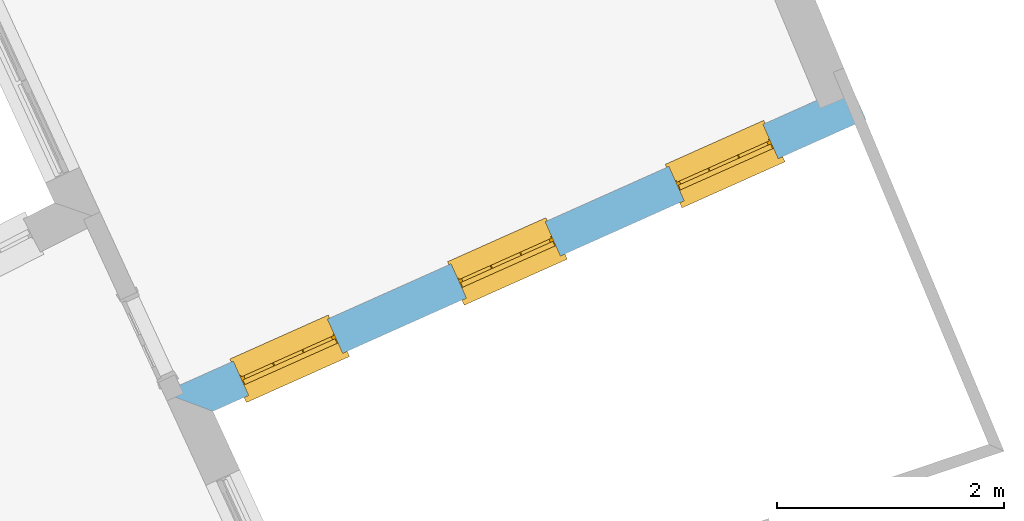
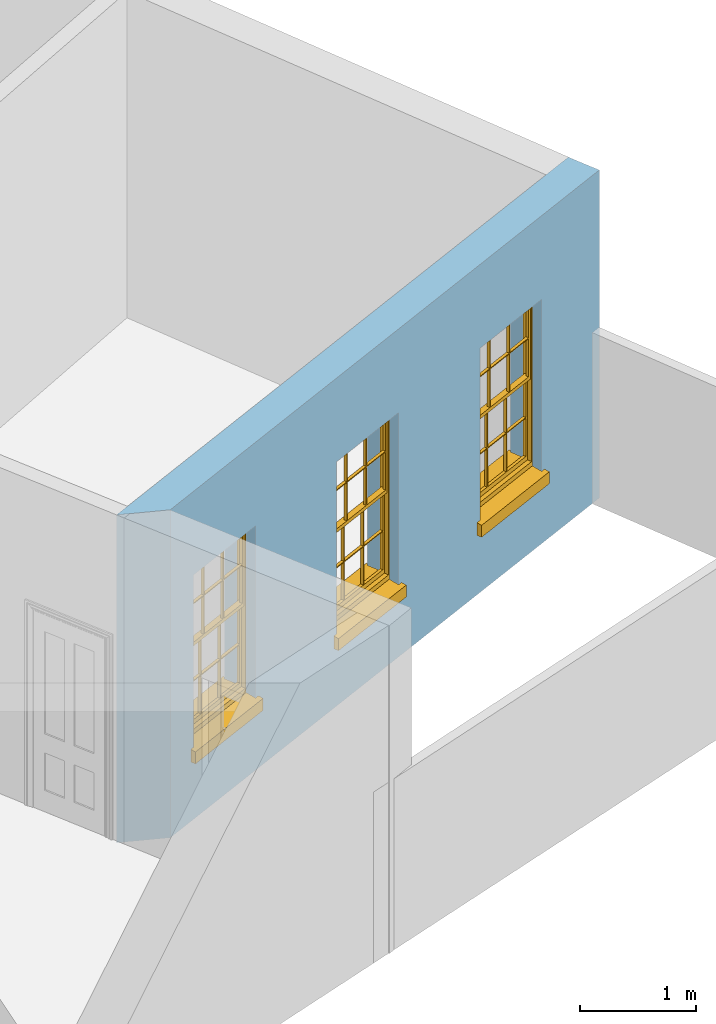
# One storey, part 6 of 10: 3 windows, 3 openings, plus 1 element that does not belong to this part.
"""IFC2X3 building model written with IfcOpenShell, lengths in metres."""

import ifcopenshell
import ifcopenshell.guid

model = None  # the IFC model being written
_history = None  # IfcOwnerHistory: only IFC2X3 demands one
_inside = {}  # id of a spatial element -> (the spatial element, [elements in it])
_under = {}  # id of a project, library or spatial element -> (it, [spatial elements below it])
_declared = {}  # id of a project -> (the project, [libraries it declares])
_typed = {}  # id of a type object -> (the type object, [elements of that type])
_made_of = {}  # id of a material, layer set ... -> (it, [elements and type objects made of it])


def new_model(schema):
    """Start an empty IFC model of exactly this schema.

    Asked for "IFC4X3", IfcOpenShell would pick the latest addendum, in which some entities
    have other attributes; the version numbers below select the first issue.
    IFC2X3 requires an IfcOwnerHistory on every rooted entity: one is made here for all.
    """
    global model, _history
    if schema == "IFC4X3":
        model = ifcopenshell.file(schema_version=(4, 3, 0, 0))
    else:
        model = ifcopenshell.file(schema=schema)
    _inside.clear()
    _under.clear()
    _declared.clear()
    _typed.clear()
    _made_of.clear()
    _history = None
    if model.schema == "IFC2X3":
        org = make("IfcOrganization", Name="unknown")
        user = make(
            "IfcPersonAndOrganization",
            ThePerson=make("IfcPerson", FamilyName="unknown"),
            TheOrganization=org,
        )
        app = make(
            "IfcApplication",
            ApplicationDeveloper=org,
            Version="unknown",
            ApplicationFullName="unknown",
            ApplicationIdentifier="unknown",
        )
        _history = make(
            "IfcOwnerHistory",
            OwningUser=user,
            OwningApplication=app,
            ChangeAction="ADDED",
            CreationDate=0,
        )
    return model


def make(cls, **values):
    """One entity of the class cls with the attributes given. An attribute that is None is left unset."""
    return model.create_entity(
        cls, **{name: value for name, value in values.items() if value is not None}
    )


def rooted(cls, **values):
    """An entity with a GlobalId (a new one), such as an element, a storey or a relation."""
    return make(cls, GlobalId=ifcopenshell.guid.new(), OwnerHistory=_history, **values)


def si_unit(unit_type, name, prefix=None):
    """IfcSIUnit, for example si_unit("LENGTHUNIT", "METRE", prefix="MILLI")."""
    return make("IfcSIUnit", UnitType=unit_type, Prefix=prefix, Name=name)


def assignment(units):
    """IfcUnitAssignment: the units of a project."""
    return None if units is None else make("IfcUnitAssignment", Units=units)


def point(xyz):
    """IfcCartesianPoint."""
    return None if xyz is None else make("IfcCartesianPoint", Coordinates=xyz)


def direction(xyz):
    """IfcDirection."""
    return None if xyz is None else make("IfcDirection", DirectionRatios=xyz)


def frame(location, z_axis=None, x_axis=None):
    """IfcAxis2Placement3D, a coordinate frame: its origin and axes. An axis left out is left unset."""
    return make(
        "IfcAxis2Placement3D",
        Location=point(location),
        Axis=direction(z_axis),
        RefDirection=direction(x_axis),
    )


def origin():
    """The frame at (0, 0, 0) with its axes left unset."""
    return frame((0.0, 0.0, 0.0))


def place(relative_to, where):
    """IfcLocalPlacement: puts the frame where relative to a parent placement (None: the world)."""
    return make(
        "IfcLocalPlacement", PlacementRelTo=relative_to, RelativePlacement=where
    )


def context(
    kind, dimensions, precision=None, world=None, true_north=None, identifier=None
):
    """IfcGeometricRepresentationContext, for example the 3D "Model" context."""
    return make(
        "IfcGeometricRepresentationContext",
        ContextIdentifier=identifier,
        ContextType=kind,
        CoordinateSpaceDimension=dimensions,
        Precision=precision,
        WorldCoordinateSystem=world,
        TrueNorth=true_north,
    )


def subcontext(parent, identifier, kind, view, scale=None):
    """IfcGeometricRepresentationSubContext, for example "Body" below "Model"."""
    return make(
        "IfcGeometricRepresentationSubContext",
        ContextIdentifier=identifier,
        ContextType=kind,
        ParentContext=parent,
        TargetScale=scale,
        TargetView=view,
    )


def project(units=None, contexts=None):
    """IfcProject with its units and contexts."""
    return rooted(
        "IfcProject",
        Name="project",
        RepresentationContexts=contexts,
        UnitsInContext=assignment(units),
    )


def spatial(cls, under=None, at=None, **own):
    """A site, building, storey or space (cls), placed at a placement, below another one or the project."""
    s = rooted(cls, ObjectPlacement=at, **own)
    if under is not None:
        _under.setdefault(under.id(), (under, []))[1].append(s)
    return s


def polyline(points):
    """IfcPolyline through the points."""
    return make("IfcPolyline", Points=[point(p) for p in points])


def outline(outer, holes=None, kind="AREA"):
    """IfcArbitraryClosedProfileDef: a profile drawn as a closed curve; with holes, ...WithVoids."""
    if holes is None:
        return make("IfcArbitraryClosedProfileDef", ProfileType=kind, OuterCurve=outer)
    return make(
        "IfcArbitraryProfileDefWithVoids",
        ProfileType=kind,
        OuterCurve=outer,
        InnerCurves=holes,
    )


def extrude(swept, where, along, depth):
    """IfcExtrudedAreaSolid: the profile swept, set in the frame where, extruded along a direction by depth."""
    return make(
        "IfcExtrudedAreaSolid",
        SweptArea=swept,
        Position=where,
        ExtrudedDirection=direction(along),
        Depth=depth,
    )


def faces_of(points, faces, orient=None, outer=None):
    """IfcFace entities. A face is a list of loops; a loop is a list of indices into points, from 0.

    orient and outer hold one flag for each loop. By default every Orientation is true, the
    first loop of a face is its IfcFaceOuterBound and the others are IfcFaceBound.
    """
    made = []
    for i, loops in enumerate(faces):
        bounds = []
        for j, loop in enumerate(loops):
            is_outer = j == 0 if outer is None else outer[i][j]
            bounds.append(
                make(
                    "IfcFaceOuterBound" if is_outer else "IfcFaceBound",
                    Bound=make("IfcPolyLoop", Polygon=[points[k] for k in loop]),
                    Orientation=True if orient is None else orient[i][j],
                )
            )
        made.append(make("IfcFace", Bounds=bounds))
    return made


def faceted_brep(points, faces, orient=None, outer=None, voids=None):
    """IfcFacetedBrep: a solid bounded by flat faces; with voids (closed shells), ...WithVoids."""
    shared = [point(p) for p in points]
    hull = make("IfcClosedShell", CfsFaces=faces_of(shared, faces, orient, outer))
    if voids is None:
        return make("IfcFacetedBrep", Outer=hull)
    return make(
        "IfcFacetedBrepWithVoids",
        Outer=hull,
        Voids=[
            make(cls, CfsFaces=faces_of(shared, fs, o, b)) for cls, fs, o, b in voids
        ],
    )


def shape(context_of_items, identifier, shape_type, items):
    """IfcShapeRepresentation: the items that make up one representation, for example the "Body"."""
    return make(
        "IfcShapeRepresentation",
        ContextOfItems=context_of_items,
        RepresentationIdentifier=identifier,
        RepresentationType=shape_type,
        Items=items,
    )


def material(Name=None, Category=None):
    """IfcMaterial."""
    return make("IfcMaterial", Name=Name, Category=Category)


def layer(
    of_material, thickness, ventilated=None, Name=None, Category=None, Priority=None
):
    """IfcMaterialLayer: one layer of a wall or slab, of a material (None: an air gap)."""
    return make(
        "IfcMaterialLayer",
        Material=of_material,
        LayerThickness=thickness,
        IsVentilated=ventilated,
        Name=Name,
        Category=Category,
        Priority=Priority,
    )


def layer_set(layers, Name=None):
    """IfcMaterialLayerSet."""
    return make("IfcMaterialLayerSet", MaterialLayers=layers, LayerSetName=Name)


def layer_usage(for_layer_set, set_direction, sense, offset, extent=None):
    """IfcMaterialLayerSetUsage: how a layer set lies in its element."""
    return make(
        "IfcMaterialLayerSetUsage",
        ForLayerSet=for_layer_set,
        LayerSetDirection=set_direction,
        DirectionSense=sense,
        OffsetFromReferenceLine=offset,
        ReferenceExtent=extent,
    )


def made_of(thing, what):
    """Note that an element or type object is made of a material, layer set ...; save() writes the relation."""
    if what is not None:
        _made_of.setdefault(what.id(), (what, []))[1].append(thing)
    return thing


def element(
    cls,
    number,
    at=None,
    inside=None,
    cuts=None,
    type_object=None,
    material=None,
    context=None,
    identifier="Body",
    shape_type=None,
    held_by="IfcProductDefinitionShape",
    body=None,
    shapes=None,
    **own,
):
    """One element of the class cls, such as IfcWall. Its Tag is "e" and its number.

    at: its placement. inside: the storey or other place that contains it. cuts: it is an
    opening in that element (IfcRelVoidsElement). A single representation is given by context,
    identifier, shape_type and body (its items); several are given by shapes. held_by: the class
    of the entity that holds the representations. save() writes the other relations.
    """
    e = rooted(cls, Tag="e%d" % number, ObjectPlacement=at, **own)
    if body is not None:
        shapes = [shape(context, identifier, shape_type, body)]
    if shapes is not None:
        e.Representation = make(held_by, Representations=shapes)
    if inside is not None:
        _inside.setdefault(inside.id(), (inside, []))[1].append(e)
    if cuts is not None:
        rooted(
            "IfcRelVoidsElement", RelatingBuildingElement=cuts, RelatedOpeningElement=e
        )
    if type_object is not None:
        _typed.setdefault(type_object.id(), (type_object, []))[1].append(e)
    return made_of(e, material)


def fill(opening, filler):
    """IfcRelFillsElement: the door or window that sits in an opening."""
    return rooted(
        "IfcRelFillsElement",
        RelatingOpeningElement=opening,
        RelatedBuildingElement=filler,
    )


def aggregate(whole, parts):
    """IfcRelAggregates: a whole, such as a stair, and the parts it consists of."""
    return rooted("IfcRelAggregates", RelatingObject=whole, RelatedObjects=parts)


def save(model, path):
    """Write the relations noted so far, then the file.

    IfcRelAggregates (storeys below a building ...), IfcRelContainedInSpatialStructure (elements
    in a storey), IfcRelDefinesByType, IfcRelAssociatesMaterial and IfcRelDeclares: one each for
    every whole, place, type object, material and project.
    """
    for whole, parts in _under.values():
        aggregate(whole, parts)
    for where, things in _inside.values():
        rooted(
            "IfcRelContainedInSpatialStructure",
            RelatedElements=things,
            RelatingStructure=where,
        )
    for kind, things in _typed.values():
        rooted("IfcRelDefinesByType", RelatedObjects=things, RelatingType=kind)
    for what, things in _made_of.values():
        rooted("IfcRelAssociatesMaterial", RelatedObjects=things, RelatingMaterial=what)
    for by, libraries in _declared.values():
        rooted("IfcRelDeclares", RelatingContext=by, RelatedDefinitions=libraries)
    model.write(path)


model = new_model("IFC2X3")

# Units and contexts
model_context = context("Model", 3, world=origin())
body_context = subcontext(model_context, "Body", "Model", "MODEL_VIEW")
ifc_project = project(units=[si_unit("PLANEANGLEUNIT", "RADIAN"), si_unit("MASSUNIT", "GRAM", prefix="KILO"), si_unit("FORCEUNIT", "NEWTON", prefix="KILO"), si_unit("LENGTHUNIT", "METRE")], contexts=[model_context])

# Site, building, storey
site_placement = place(None, origin())
site = spatial("IfcSite", under=ifc_project, at=site_placement, CompositionType="ELEMENT")
building_placement = place(None, origin())
building = spatial("IfcBuilding", under=site, at=building_placement, Name="Building plot-8", CompositionType="ELEMENT")
storey_placement = place(None, origin())
storey = spatial("IfcBuildingStorey", under=building, at=storey_placement, Name="Floor 0", CompositionType="ELEMENT", Elevation=0.0)

# Wall, openings, windows
ifc_material = material(Name="Masonry")
ifc_layer = layer(ifc_material, 0.33, ventilated=False)
ifc_layer_set = layer_set([ifc_layer], Name="My Wall")
ifc_layer_usage = layer_usage(ifc_layer_set, "AXIS2", "NEGATIVE", 0.08)
wall_placement = place(storey_placement, origin())
wall = element("IfcWallStandardCase", 1, at=wall_placement, inside=storey, material=ifc_layer_usage, Name="exterior", context=body_context, shape_type="SweptSolid", body=[
    extrude(outline(polyline([(25.5427100949966, 9.06939881204675), (25.9819110894624, 8.90425989939787), (31.7366248764663, 11.4767371568641), (31.6019513234471, 11.778006196291), (25.5427100949966, 9.06939881204675)])), origin(), (0.0, 0.0, 1.0), 3.45),
])
opening_1_placement = place(storey_placement, frame((0.0, 0.0, 0.75)))
opening_1 = element("IfcOpeningElement", 2, at=opening_1_placement, cuts=wall, Name="Opening", ObjectType="Opening", context=body_context, shape_type="SweptSolid", body=[
    extrude(outline(polyline([(26.2953527613871, 9.04437487338484), (27.1261249610187, 9.41574739837715), (26.9914514079996, 9.71701643780401), (26.1606792083679, 9.34564391281171), (26.2953527613871, 9.04437487338484)])), origin(), (0.0, 0.0, 1.0), 1.82),
])
opening_2_placement = place(storey_placement, frame((0.0, 0.0, 0.75)))
opening_2 = element("IfcOpeningElement", 3, at=opening_2_placement, cuts=wall, Name="Opening", ObjectType="Opening", context=body_context, shape_type="SweptSolid", body=[
    extrude(outline(polyline([(28.2144135191812, 9.90223511419651), (29.0451857188129, 10.2736076391888), (28.9105121657937, 10.5748766786157), (28.0797399661621, 10.2035041536234), (28.2144135191812, 9.90223511419651)])), origin(), (0.0, 0.0, 1.0), 1.82),
])
opening_3_placement = place(storey_placement, frame((0.0, 0.0, 0.75)))
opening_3 = element("IfcOpeningElement", 4, at=opening_3_placement, cuts=wall, Name="Opening", ObjectType="Opening", context=body_context, shape_type="SweptSolid", body=[
    extrude(outline(polyline([(30.1334742769754, 10.7600953550082), (30.9642464766071, 11.1314678800005), (30.8295729235879, 11.4327369194274), (29.9988007239562, 11.0613643944351), (30.1334742769754, 10.7600953550082)])), origin(), (0.0, 0.0, 1.0), 1.82),
])
window_1_placement = place(storey_placement, frame((26.1933273424331, 9.27260899416277, 0.75), z_axis=(0.0, 0.0, 1.0), x_axis=(0.830772199631671, 0.371372524992305, 0.0)))
window_1 = element("IfcWindow", 5, at=window_1_placement, inside=storey, Name="living window", OverallHeight=1.82, OverallWidth=0.91, context=body_context, shape_type="Brep", held_by="IfcProductRepresentation", body=[
    faceted_brep([(0.033125, -0.105, 0.975209), (0.01, -0.105, 0.975209), (0.033125, -0.105, 1.376042), (0.876875, -0.105, 0.975209), (0.876875, -0.105, 1.376042), (0.9, -0.105, 0.975209), (0.876875, -0.105, 1.386042), (0.876875, -0.105, 1.786875), (0.9, -0.105, 1.81), (0.033125, -0.105, 1.786875), (0.033125, -0.105, 1.386042), (0.01, -0.105, 1.81), (0.876875, -0.135, 1.376042), (0.876875, -0.135, 0.975209), (0.9, -0.135, 0.937083), (0.033125, -0.135, 1.786875), (0.01, -0.135, 1.81), (0.033125, -0.135, 1.386042), (0.01, -0.135, 0.937083), (0.033125, -0.135, 0.975209), (0.033125, -0.135, 1.376042), (0.876875, -0.135, 1.786875), (0.876875, -0.135, 1.386042), (0.9, -0.135, 1.81), (0.033125, -0.105, 0.937083), (0.01, -0.105, 0.937083), (0.033125, -0.105, 0.53625), (0.876875, -0.105, 0.937083), (0.876875, -0.105, 0.53625), (0.9, -0.105, 0.937083), (0.876875, -0.105, 0.52625), (0.876875, -0.105, 0.125417), (0.9, -0.105, 0.077167), (0.033125, -0.105, 0.125417), (0.033125, -0.105, 0.52625), (0.01, -0.105, 0.077167), (-0.0425, -0.25, 0.01), (-0.0425, -0.3, 0.001667), (0.0, -0.25, 0.01), (0.9525, -0.25, 0.01), (0.91, -0.25, 0.01), (0.9525, -0.3, 0.001667), (-0.02, 0.08, 0.077167), (0.0, 0.08, 0.077167), (-0.02, 0.11, 0.077167), (0.0, -0.06, 0.077167), (0.01, -0.06, 0.077167), (0.91, -0.06, 0.077167), (0.91, 0.08, 0.077167), (0.9, -0.06, 0.077167), (0.93, 0.08, 0.077167), (0.93, 0.11, 0.077167), (0.01, -0.075, 0.975209), (0.9, -0.075, 0.975209), (0.876875, -0.075, 0.125417), (0.876875, -0.075, 0.52625), (0.9, -0.075, 0.077167), (0.876875, -0.075, 0.53625), (0.876875, -0.075, 0.937083), (0.033125, -0.075, 0.125417), (0.01, -0.075, 0.077167), (0.033125, -0.075, 0.52625), (0.033125, -0.075, 0.937083), (0.033125, -0.075, 0.53625), (-0.02, 0.08, 0.052167), (-0.02, 0.11, 0.052167), (0.93, 0.11, 0.052167), (0.93, 0.08, 0.052167), (0.91, 0.08, 0.052167), (0.0, 0.08, 0.052167), (0.91, -0.15, 0.026667), (0.0, -0.15, 0.026667), (-0.0425, -0.3, -0.123333), (0.9525, -0.3, -0.123333), (-0.0425, -0.25, -0.123333), (0.9525, -0.25, -0.123333), (0.01, -0.06, 1.81), (0.9, -0.06, 1.81), (0.0, -0.06, 1.82), (0.91, -0.06, 1.82), (0.01, -0.15, 0.077167), (0.9, -0.15, 0.077167), (0.592292, -0.105, 0.125417), (0.592292, -0.075, 0.125417), (0.317708, -0.075, 0.125417), (0.317708, -0.105, 0.125417), (0.592292, -0.105, 0.53625), (0.317708, -0.105, 0.53625), (0.317708, -0.105, 0.52625), (0.592292, -0.105, 0.52625), (0.592292, -0.075, 0.53625), (0.317708, -0.075, 0.53625), (0.592292, -0.135, 1.386042), (0.592292, -0.105, 1.386042), (0.317708, -0.105, 1.386042), (0.317708, -0.135, 1.386042), (0.317708, -0.135, 1.376042), (0.592292, -0.135, 1.376042), (0.317708, -0.105, 1.376042), (0.592292, -0.105, 1.376042), (0.602292, -0.135, 1.376042), (0.592292, -0.135, 0.975209), (0.602292, -0.135, 0.975209), (0.602292, -0.105, 0.975209), (0.592292, -0.105, 0.975209), (0.602292, -0.105, 1.376042), (0.602292, -0.075, 0.53625), (0.602292, -0.105, 0.53625), (0.317708, -0.075, 0.52625), (0.307708, -0.075, 0.125417), (0.307708, -0.075, 0.52625), (0.602292, -0.075, 0.52625), (0.602292, -0.075, 0.125417), (0.592292, -0.075, 0.52625), (0.307708, -0.075, 0.53625), (0.317708, -0.075, 0.937083), (0.307708, -0.075, 0.937083), (0.602292, -0.075, 0.937083), (0.592292, -0.075, 0.937083), (0.307708, -0.105, 0.52625), (0.307708, -0.105, 0.125417), (0.307708, -0.105, 0.53625), (0.307708, -0.105, 0.937083), (0.592292, -0.105, 0.937083), (0.317708, -0.105, 0.937083), (0.602292, -0.105, 0.937083), (0.602292, -0.105, 0.52625), (0.602292, -0.105, 0.125417), (0.307708, -0.135, 1.386042), (0.307708, -0.135, 1.376042), (0.307708, -0.135, 0.975209), (0.317708, -0.135, 0.975209), (0.317708, -0.135, 1.786875), (0.307708, -0.135, 1.786875), (0.602292, -0.135, 1.786875), (0.592292, -0.135, 1.786875), (0.602292, -0.135, 1.386042), (0.602292, -0.105, 1.386042), (0.307708, -0.105, 1.386042), (0.307708, -0.105, 1.786875), (0.317708, -0.105, 1.786875), (0.592292, -0.105, 1.786875), (0.602292, -0.105, 1.786875), (0.307708, -0.105, 1.376042), (0.317708, -0.105, 0.975209), (0.307708, -0.105, 0.975209), (0.91, -0.15, 1.82), (0.9, -0.15, 1.81), (0.01, -0.15, 1.81), (0.0, -0.15, 1.82), (0.91, -0.25, 0.0), (0.0, -0.25, 0.0), (0.91, 0.08, 0.0), (0.0, 0.08, 0.0)], [[[0, 1, 2]], [[3, 4, 5]], [[6, 7, 8]], [[9, 10, 11]], [[12, 13, 14]], [[15, 16, 17]], [[18, 19, 20]], [[21, 22, 23]], [[24, 25, 26]], [[27, 28, 29]], [[30, 31, 32]], [[33, 34, 35]], [[14, 27, 29]], [[25, 24, 18]], [[36, 37, 38]], [[39, 40, 41]], [[42, 43, 44]], [[45, 46, 43]], [[47, 48, 49]], [[50, 51, 48]], [[1, 0, 52]], [[5, 53, 3]], [[54, 55, 56]], [[57, 58, 53]], [[59, 60, 61]], [[62, 63, 52]], [[48, 43, 46, 49]], [[51, 44, 43, 48]], [[64, 42, 44, 65]], [[65, 44, 51, 66]], [[66, 51, 50, 67]], [[65, 66, 68, 69]], [[60, 56, 49, 46]], [[70, 71, 38, 40]], [[37, 41, 40, 38]], [[37, 72, 73, 41]], [[74, 75, 73, 72]], [[8, 11, 76, 77]], [[76, 78, 79, 77]], [[32, 35, 80, 81]], [[81, 80, 71, 70]], [[82, 83, 84, 85]], [[86, 87, 88, 89]], [[86, 90, 91, 87]], [[92, 93, 94, 95]], [[92, 95, 96, 97]], [[96, 98, 99, 97]], [[100, 97, 101, 102]], [[103, 104, 99, 105]], [[97, 99, 104, 101]], [[102, 103, 105, 100]], [[28, 57, 106, 107]], [[108, 84, 109, 110]], [[111, 112, 83, 113]], [[114, 110, 61, 63]], [[90, 113, 108, 91]], [[115, 91, 114, 116]], [[117, 106, 90, 118]], [[111, 106, 57, 55]], [[119, 110, 109, 120]], [[34, 61, 110, 119]], [[89, 113, 83, 82]], [[88, 108, 113, 89]], [[85, 84, 108, 88]], [[121, 114, 63, 26]], [[122, 116, 114, 121]], [[123, 118, 90, 86]], [[87, 91, 115, 124]], [[107, 106, 117, 125]], [[126, 111, 55, 30]], [[127, 112, 111, 126]], [[126, 30, 28, 107]], [[88, 119, 120, 85]], [[126, 89, 82, 127]], [[125, 123, 86, 107]], [[121, 26, 34, 119]], [[124, 122, 121, 87]], [[128, 17, 20, 129]], [[96, 129, 130, 131]], [[132, 133, 128, 95]], [[134, 135, 92, 136]], [[100, 12, 22, 136]], [[137, 6, 4, 105]], [[94, 138, 139, 140]], [[137, 93, 141, 142]], [[99, 98, 94, 93]], [[143, 2, 10, 138]], [[144, 145, 143, 98]], [[129, 143, 145, 130]], [[20, 2, 143, 129]], [[131, 144, 98, 96]], [[128, 138, 10, 17]], [[133, 139, 138, 128]], [[135, 141, 93, 92]], [[95, 94, 140, 132]], [[22, 6, 137, 136]], [[136, 137, 142, 134]], [[100, 105, 4, 12]], [[107, 86, 89, 126]], [[106, 111, 113, 90]], [[91, 108, 110, 114]], [[87, 121, 119, 88]], [[97, 100, 136, 92]], [[129, 96, 95, 128]], [[98, 143, 138, 94]], [[105, 99, 93, 137]], [[131, 101, 104, 144]], [[124, 115, 118, 123]], [[132, 140, 141, 135]], [[120, 109, 59, 33]], [[15, 9, 139, 133]], [[134, 142, 7, 21]], [[31, 54, 112, 127]], [[36, 74, 72, 37]], [[39, 41, 73, 75]], [[18, 14, 101, 131]], [[23, 16, 132, 135]], [[83, 56, 60, 84]], [[52, 53, 118, 115]], [[53, 52, 144, 104]], [[11, 8, 141, 140]], [[14, 18, 124, 123]], [[2, 1, 11, 10]], [[8, 5, 4, 6]], [[57, 53, 56, 55]], [[60, 52, 63, 61]], [[26, 25, 35, 34]], [[32, 29, 28, 30]], [[14, 23, 22, 12]], [[18, 20, 17, 16]], [[19, 0, 2, 20]], [[17, 10, 9, 15]], [[12, 4, 3, 13]], [[21, 7, 6, 22]], [[27, 58, 57, 28]], [[30, 55, 54, 31]], [[33, 59, 61, 34]], [[26, 63, 62, 24]], [[5, 8, 77, 53]], [[76, 11, 1, 52]], [[46, 45, 78, 76]], [[49, 77, 79, 47]], [[70, 146, 147, 81]], [[71, 80, 148, 149]], [[19, 130, 145, 0]], [[102, 13, 3, 103]], [[116, 122, 24, 62]], [[29, 32, 81, 14]], [[80, 35, 25, 18]], [[60, 46, 76, 52]], [[77, 49, 56, 53]], [[23, 14, 81, 147]], [[16, 148, 80, 18]], [[35, 85, 120]], [[120, 33, 35]], [[127, 82, 32]], [[32, 31, 127]], [[32, 82, 85, 35]], [[102, 101, 14]], [[14, 13, 102]], [[18, 131, 130]], [[130, 19, 18]], [[134, 21, 23]], [[23, 135, 134]], [[16, 15, 133]], [[133, 132, 16]], [[11, 140, 139]], [[139, 9, 11]], [[142, 141, 8]], [[8, 7, 142]], [[23, 147, 148, 16]], [[146, 149, 148, 147]], [[52, 115, 116]], [[116, 62, 52]], [[118, 53, 117]], [[58, 117, 53]], [[27, 125, 117, 58]], [[56, 83, 112]], [[112, 54, 56]], [[109, 84, 60]], [[60, 59, 109]], [[125, 27, 14]], [[14, 123, 125]], [[122, 124, 18]], [[18, 24, 122]], [[145, 144, 52]], [[52, 0, 145]], [[103, 3, 53]], [[53, 104, 103]], [[79, 78, 149, 146]], [[78, 45, 71, 149]], [[146, 70, 47, 79]], [[150, 75, 74, 151]], [[68, 66, 67]], [[48, 68, 67, 50]], [[69, 64, 65]], [[42, 64, 69, 43]], [[69, 68, 152, 153]], [[70, 68, 48, 47]], [[150, 152, 68, 70]], [[43, 69, 71, 45]], [[69, 153, 151, 71]], [[152, 150, 151, 153]], [[38, 151, 74, 36]], [[71, 151, 38]], [[39, 75, 150, 40]], [[40, 150, 70]]]),
])
fill(opening_1, window_1)
window_2_placement = place(storey_placement, frame((28.1123881002273, 10.1304692349744, 0.75), z_axis=(0.0, 0.0, 1.0), x_axis=(0.830772199631671, 0.371372524992303, 0.0)))
window_2 = element("IfcWindow", 6, at=window_2_placement, inside=storey, Name="living window", OverallHeight=1.82, OverallWidth=0.91, context=body_context, shape_type="Brep", held_by="IfcProductRepresentation", body=[
    faceted_brep([(0.033125, -0.105, 0.975209), (0.01, -0.105, 0.975209), (0.033125, -0.105, 1.376042), (0.876875, -0.105, 0.975209), (0.876875, -0.105, 1.376042), (0.9, -0.105, 0.975209), (0.876875, -0.105, 1.386042), (0.876875, -0.105, 1.786875), (0.9, -0.105, 1.81), (0.033125, -0.105, 1.786875), (0.033125, -0.105, 1.386042), (0.01, -0.105, 1.81), (0.876875, -0.135, 1.376042), (0.876875, -0.135, 0.975209), (0.9, -0.135, 0.937083), (0.033125, -0.135, 1.786875), (0.01, -0.135, 1.81), (0.033125, -0.135, 1.386042), (0.01, -0.135, 0.937083), (0.033125, -0.135, 0.975209), (0.033125, -0.135, 1.376042), (0.876875, -0.135, 1.786875), (0.876875, -0.135, 1.386042), (0.9, -0.135, 1.81), (0.033125, -0.105, 0.937083), (0.01, -0.105, 0.937083), (0.033125, -0.105, 0.53625), (0.876875, -0.105, 0.937083), (0.876875, -0.105, 0.53625), (0.9, -0.105, 0.937083), (0.876875, -0.105, 0.52625), (0.876875, -0.105, 0.125417), (0.9, -0.105, 0.077167), (0.033125, -0.105, 0.125417), (0.033125, -0.105, 0.52625), (0.01, -0.105, 0.077167), (-0.0425, -0.25, 0.01), (-0.0425, -0.3, 0.001667), (0.0, -0.25, 0.01), (0.9525, -0.25, 0.01), (0.91, -0.25, 0.01), (0.9525, -0.3, 0.001667), (-0.02, 0.08, 0.077167), (0.0, 0.08, 0.077167), (-0.02, 0.11, 0.077167), (0.0, -0.06, 0.077167), (0.01, -0.06, 0.077167), (0.91, -0.06, 0.077167), (0.91, 0.08, 0.077167), (0.9, -0.06, 0.077167), (0.93, 0.08, 0.077167), (0.93, 0.11, 0.077167), (0.01, -0.075, 0.975209), (0.9, -0.075, 0.975209), (0.876875, -0.075, 0.125417), (0.876875, -0.075, 0.52625), (0.9, -0.075, 0.077167), (0.876875, -0.075, 0.53625), (0.876875, -0.075, 0.937083), (0.033125, -0.075, 0.125417), (0.01, -0.075, 0.077167), (0.033125, -0.075, 0.52625), (0.033125, -0.075, 0.937083), (0.033125, -0.075, 0.53625), (-0.02, 0.08, 0.052167), (-0.02, 0.11, 0.052167), (0.93, 0.11, 0.052167), (0.93, 0.08, 0.052167), (0.91, 0.08, 0.052167), (0.0, 0.08, 0.052167), (0.91, -0.15, 0.026667), (0.0, -0.15, 0.026667), (-0.0425, -0.3, -0.123333), (0.9525, -0.3, -0.123333), (-0.0425, -0.25, -0.123333), (0.9525, -0.25, -0.123333), (0.01, -0.06, 1.81), (0.9, -0.06, 1.81), (0.0, -0.06, 1.82), (0.91, -0.06, 1.82), (0.01, -0.15, 0.077167), (0.9, -0.15, 0.077167), (0.592292, -0.105, 0.125417), (0.592292, -0.075, 0.125417), (0.317708, -0.075, 0.125417), (0.317708, -0.105, 0.125417), (0.592292, -0.105, 0.53625), (0.317708, -0.105, 0.53625), (0.317708, -0.105, 0.52625), (0.592292, -0.105, 0.52625), (0.592292, -0.075, 0.53625), (0.317708, -0.075, 0.53625), (0.592292, -0.135, 1.386042), (0.592292, -0.105, 1.386042), (0.317708, -0.105, 1.386042), (0.317708, -0.135, 1.386042), (0.317708, -0.135, 1.376042), (0.592292, -0.135, 1.376042), (0.317708, -0.105, 1.376042), (0.592292, -0.105, 1.376042), (0.602292, -0.135, 1.376042), (0.592292, -0.135, 0.975209), (0.602292, -0.135, 0.975209), (0.602292, -0.105, 0.975209), (0.592292, -0.105, 0.975209), (0.602292, -0.105, 1.376042), (0.602292, -0.075, 0.53625), (0.602292, -0.105, 0.53625), (0.317708, -0.075, 0.52625), (0.307708, -0.075, 0.125417), (0.307708, -0.075, 0.52625), (0.602292, -0.075, 0.52625), (0.602292, -0.075, 0.125417), (0.592292, -0.075, 0.52625), (0.307708, -0.075, 0.53625), (0.317708, -0.075, 0.937083), (0.307708, -0.075, 0.937083), (0.602292, -0.075, 0.937083), (0.592292, -0.075, 0.937083), (0.307708, -0.105, 0.52625), (0.307708, -0.105, 0.125417), (0.307708, -0.105, 0.53625), (0.307708, -0.105, 0.937083), (0.592292, -0.105, 0.937083), (0.317708, -0.105, 0.937083), (0.602292, -0.105, 0.937083), (0.602292, -0.105, 0.52625), (0.602292, -0.105, 0.125417), (0.307708, -0.135, 1.386042), (0.307708, -0.135, 1.376042), (0.307708, -0.135, 0.975209), (0.317708, -0.135, 0.975209), (0.317708, -0.135, 1.786875), (0.307708, -0.135, 1.786875), (0.602292, -0.135, 1.786875), (0.592292, -0.135, 1.786875), (0.602292, -0.135, 1.386042), (0.602292, -0.105, 1.386042), (0.307708, -0.105, 1.386042), (0.307708, -0.105, 1.786875), (0.317708, -0.105, 1.786875), (0.592292, -0.105, 1.786875), (0.602292, -0.105, 1.786875), (0.307708, -0.105, 1.376042), (0.317708, -0.105, 0.975209), (0.307708, -0.105, 0.975209), (0.91, -0.15, 1.82), (0.9, -0.15, 1.81), (0.01, -0.15, 1.81), (0.0, -0.15, 1.82), (0.91, -0.25, 0.0), (0.0, -0.25, 0.0), (0.91, 0.08, 0.0), (0.0, 0.08, 0.0)], [[[0, 1, 2]], [[3, 4, 5]], [[6, 7, 8]], [[9, 10, 11]], [[12, 13, 14]], [[15, 16, 17]], [[18, 19, 20]], [[21, 22, 23]], [[24, 25, 26]], [[27, 28, 29]], [[30, 31, 32]], [[33, 34, 35]], [[14, 27, 29]], [[25, 24, 18]], [[36, 37, 38]], [[39, 40, 41]], [[42, 43, 44]], [[45, 46, 43]], [[47, 48, 49]], [[50, 51, 48]], [[1, 0, 52]], [[5, 53, 3]], [[54, 55, 56]], [[57, 58, 53]], [[59, 60, 61]], [[62, 63, 52]], [[48, 43, 46, 49]], [[51, 44, 43, 48]], [[64, 42, 44, 65]], [[65, 44, 51, 66]], [[66, 51, 50, 67]], [[65, 66, 68, 69]], [[60, 56, 49, 46]], [[70, 71, 38, 40]], [[37, 41, 40, 38]], [[37, 72, 73, 41]], [[74, 75, 73, 72]], [[8, 11, 76, 77]], [[76, 78, 79, 77]], [[32, 35, 80, 81]], [[81, 80, 71, 70]], [[82, 83, 84, 85]], [[86, 87, 88, 89]], [[86, 90, 91, 87]], [[92, 93, 94, 95]], [[92, 95, 96, 97]], [[96, 98, 99, 97]], [[100, 97, 101, 102]], [[103, 104, 99, 105]], [[97, 99, 104, 101]], [[102, 103, 105, 100]], [[28, 57, 106, 107]], [[108, 84, 109, 110]], [[111, 112, 83, 113]], [[114, 110, 61, 63]], [[90, 113, 108, 91]], [[115, 91, 114, 116]], [[117, 106, 90, 118]], [[111, 106, 57, 55]], [[119, 110, 109, 120]], [[34, 61, 110, 119]], [[89, 113, 83, 82]], [[88, 108, 113, 89]], [[85, 84, 108, 88]], [[121, 114, 63, 26]], [[122, 116, 114, 121]], [[123, 118, 90, 86]], [[87, 91, 115, 124]], [[107, 106, 117, 125]], [[126, 111, 55, 30]], [[127, 112, 111, 126]], [[126, 30, 28, 107]], [[88, 119, 120, 85]], [[126, 89, 82, 127]], [[125, 123, 86, 107]], [[121, 26, 34, 119]], [[124, 122, 121, 87]], [[128, 17, 20, 129]], [[96, 129, 130, 131]], [[132, 133, 128, 95]], [[134, 135, 92, 136]], [[100, 12, 22, 136]], [[137, 6, 4, 105]], [[94, 138, 139, 140]], [[137, 93, 141, 142]], [[99, 98, 94, 93]], [[143, 2, 10, 138]], [[144, 145, 143, 98]], [[129, 143, 145, 130]], [[20, 2, 143, 129]], [[131, 144, 98, 96]], [[128, 138, 10, 17]], [[133, 139, 138, 128]], [[135, 141, 93, 92]], [[95, 94, 140, 132]], [[22, 6, 137, 136]], [[136, 137, 142, 134]], [[100, 105, 4, 12]], [[107, 86, 89, 126]], [[106, 111, 113, 90]], [[91, 108, 110, 114]], [[87, 121, 119, 88]], [[97, 100, 136, 92]], [[129, 96, 95, 128]], [[98, 143, 138, 94]], [[105, 99, 93, 137]], [[131, 101, 104, 144]], [[124, 115, 118, 123]], [[132, 140, 141, 135]], [[120, 109, 59, 33]], [[15, 9, 139, 133]], [[134, 142, 7, 21]], [[31, 54, 112, 127]], [[36, 74, 72, 37]], [[39, 41, 73, 75]], [[18, 14, 101, 131]], [[23, 16, 132, 135]], [[83, 56, 60, 84]], [[52, 53, 118, 115]], [[53, 52, 144, 104]], [[11, 8, 141, 140]], [[14, 18, 124, 123]], [[2, 1, 11, 10]], [[8, 5, 4, 6]], [[57, 53, 56, 55]], [[60, 52, 63, 61]], [[26, 25, 35, 34]], [[32, 29, 28, 30]], [[14, 23, 22, 12]], [[18, 20, 17, 16]], [[19, 0, 2, 20]], [[17, 10, 9, 15]], [[12, 4, 3, 13]], [[21, 7, 6, 22]], [[27, 58, 57, 28]], [[30, 55, 54, 31]], [[33, 59, 61, 34]], [[26, 63, 62, 24]], [[5, 8, 77, 53]], [[76, 11, 1, 52]], [[46, 45, 78, 76]], [[49, 77, 79, 47]], [[70, 146, 147, 81]], [[71, 80, 148, 149]], [[19, 130, 145, 0]], [[102, 13, 3, 103]], [[116, 122, 24, 62]], [[29, 32, 81, 14]], [[80, 35, 25, 18]], [[60, 46, 76, 52]], [[77, 49, 56, 53]], [[23, 14, 81, 147]], [[16, 148, 80, 18]], [[35, 85, 120]], [[120, 33, 35]], [[127, 82, 32]], [[32, 31, 127]], [[32, 82, 85, 35]], [[102, 101, 14]], [[14, 13, 102]], [[18, 131, 130]], [[130, 19, 18]], [[134, 21, 23]], [[23, 135, 134]], [[16, 15, 133]], [[133, 132, 16]], [[11, 140, 139]], [[139, 9, 11]], [[142, 141, 8]], [[8, 7, 142]], [[23, 147, 148, 16]], [[146, 149, 148, 147]], [[52, 115, 116]], [[116, 62, 52]], [[118, 53, 117]], [[58, 117, 53]], [[27, 125, 117, 58]], [[56, 83, 112]], [[112, 54, 56]], [[109, 84, 60]], [[60, 59, 109]], [[125, 27, 14]], [[14, 123, 125]], [[122, 124, 18]], [[18, 24, 122]], [[145, 144, 52]], [[52, 0, 145]], [[103, 3, 53]], [[53, 104, 103]], [[79, 78, 149, 146]], [[78, 45, 71, 149]], [[146, 70, 47, 79]], [[150, 75, 74, 151]], [[68, 66, 67]], [[48, 68, 67, 50]], [[69, 64, 65]], [[42, 64, 69, 43]], [[69, 68, 152, 153]], [[70, 68, 48, 47]], [[150, 152, 68, 70]], [[43, 69, 71, 45]], [[69, 153, 151, 71]], [[152, 150, 151, 153]], [[38, 151, 74, 36]], [[71, 151, 38]], [[39, 75, 150, 40]], [[40, 150, 70]]]),
])
fill(opening_2, window_2)
window_3_placement = place(storey_placement, frame((30.0314488580215, 10.9883294757861, 0.75), z_axis=(0.0, 0.0, 1.0), x_axis=(0.830772199631671, 0.371372524992303, 0.0)))
window_3 = element("IfcWindow", 7, at=window_3_placement, inside=storey, Name="living window", OverallHeight=1.82, OverallWidth=0.91, context=body_context, shape_type="Brep", held_by="IfcProductRepresentation", body=[
    faceted_brep([(0.033125, -0.105, 0.975209), (0.01, -0.105, 0.975209), (0.033125, -0.105, 1.376042), (0.876875, -0.105, 0.975209), (0.876875, -0.105, 1.376042), (0.9, -0.105, 0.975209), (0.876875, -0.105, 1.386042), (0.876875, -0.105, 1.786875), (0.9, -0.105, 1.81), (0.033125, -0.105, 1.786875), (0.033125, -0.105, 1.386042), (0.01, -0.105, 1.81), (0.876875, -0.135, 1.376042), (0.876875, -0.135, 0.975209), (0.9, -0.135, 0.937083), (0.033125, -0.135, 1.786875), (0.01, -0.135, 1.81), (0.033125, -0.135, 1.386042), (0.01, -0.135, 0.937083), (0.033125, -0.135, 0.975209), (0.033125, -0.135, 1.376042), (0.876875, -0.135, 1.786875), (0.876875, -0.135, 1.386042), (0.9, -0.135, 1.81), (0.033125, -0.105, 0.937083), (0.01, -0.105, 0.937083), (0.033125, -0.105, 0.53625), (0.876875, -0.105, 0.937083), (0.876875, -0.105, 0.53625), (0.9, -0.105, 0.937083), (0.876875, -0.105, 0.52625), (0.876875, -0.105, 0.125417), (0.9, -0.105, 0.077167), (0.033125, -0.105, 0.125417), (0.033125, -0.105, 0.52625), (0.01, -0.105, 0.077167), (-0.0425, -0.25, 0.01), (-0.0425, -0.3, 0.001667), (0.0, -0.25, 0.01), (0.9525, -0.25, 0.01), (0.91, -0.25, 0.01), (0.9525, -0.3, 0.001667), (-0.02, 0.08, 0.077167), (0.0, 0.08, 0.077167), (-0.02, 0.11, 0.077167), (0.0, -0.06, 0.077167), (0.01, -0.06, 0.077167), (0.91, -0.06, 0.077167), (0.91, 0.08, 0.077167), (0.9, -0.06, 0.077167), (0.93, 0.08, 0.077167), (0.93, 0.11, 0.077167), (0.01, -0.075, 0.975209), (0.9, -0.075, 0.975209), (0.876875, -0.075, 0.125417), (0.876875, -0.075, 0.52625), (0.9, -0.075, 0.077167), (0.876875, -0.075, 0.53625), (0.876875, -0.075, 0.937083), (0.033125, -0.075, 0.125417), (0.01, -0.075, 0.077167), (0.033125, -0.075, 0.52625), (0.033125, -0.075, 0.937083), (0.033125, -0.075, 0.53625), (-0.02, 0.08, 0.052167), (-0.02, 0.11, 0.052167), (0.93, 0.11, 0.052167), (0.93, 0.08, 0.052167), (0.91, 0.08, 0.052167), (0.0, 0.08, 0.052167), (0.91, -0.15, 0.026667), (0.0, -0.15, 0.026667), (-0.0425, -0.3, -0.123333), (0.9525, -0.3, -0.123333), (-0.0425, -0.25, -0.123333), (0.9525, -0.25, -0.123333), (0.01, -0.06, 1.81), (0.9, -0.06, 1.81), (0.0, -0.06, 1.82), (0.91, -0.06, 1.82), (0.01, -0.15, 0.077167), (0.9, -0.15, 0.077167), (0.592292, -0.105, 0.125417), (0.592292, -0.075, 0.125417), (0.317708, -0.075, 0.125417), (0.317708, -0.105, 0.125417), (0.592292, -0.105, 0.53625), (0.317708, -0.105, 0.53625), (0.317708, -0.105, 0.52625), (0.592292, -0.105, 0.52625), (0.592292, -0.075, 0.53625), (0.317708, -0.075, 0.53625), (0.592292, -0.135, 1.386042), (0.592292, -0.105, 1.386042), (0.317708, -0.105, 1.386042), (0.317708, -0.135, 1.386042), (0.317708, -0.135, 1.376042), (0.592292, -0.135, 1.376042), (0.317708, -0.105, 1.376042), (0.592292, -0.105, 1.376042), (0.602292, -0.135, 1.376042), (0.592292, -0.135, 0.975209), (0.602292, -0.135, 0.975209), (0.602292, -0.105, 0.975209), (0.592292, -0.105, 0.975209), (0.602292, -0.105, 1.376042), (0.602292, -0.075, 0.53625), (0.602292, -0.105, 0.53625), (0.317708, -0.075, 0.52625), (0.307708, -0.075, 0.125417), (0.307708, -0.075, 0.52625), (0.602292, -0.075, 0.52625), (0.602292, -0.075, 0.125417), (0.592292, -0.075, 0.52625), (0.307708, -0.075, 0.53625), (0.317708, -0.075, 0.937083), (0.307708, -0.075, 0.937083), (0.602292, -0.075, 0.937083), (0.592292, -0.075, 0.937083), (0.307708, -0.105, 0.52625), (0.307708, -0.105, 0.125417), (0.307708, -0.105, 0.53625), (0.307708, -0.105, 0.937083), (0.592292, -0.105, 0.937083), (0.317708, -0.105, 0.937083), (0.602292, -0.105, 0.937083), (0.602292, -0.105, 0.52625), (0.602292, -0.105, 0.125417), (0.307708, -0.135, 1.386042), (0.307708, -0.135, 1.376042), (0.307708, -0.135, 0.975209), (0.317708, -0.135, 0.975209), (0.317708, -0.135, 1.786875), (0.307708, -0.135, 1.786875), (0.602292, -0.135, 1.786875), (0.592292, -0.135, 1.786875), (0.602292, -0.135, 1.386042), (0.602292, -0.105, 1.386042), (0.307708, -0.105, 1.386042), (0.307708, -0.105, 1.786875), (0.317708, -0.105, 1.786875), (0.592292, -0.105, 1.786875), (0.602292, -0.105, 1.786875), (0.307708, -0.105, 1.376042), (0.317708, -0.105, 0.975209), (0.307708, -0.105, 0.975209), (0.91, -0.15, 1.82), (0.9, -0.15, 1.81), (0.01, -0.15, 1.81), (0.0, -0.15, 1.82), (0.91, -0.25, 0.0), (0.0, -0.25, 0.0), (0.91, 0.08, 0.0), (0.0, 0.08, 0.0)], [[[0, 1, 2]], [[3, 4, 5]], [[6, 7, 8]], [[9, 10, 11]], [[12, 13, 14]], [[15, 16, 17]], [[18, 19, 20]], [[21, 22, 23]], [[24, 25, 26]], [[27, 28, 29]], [[30, 31, 32]], [[33, 34, 35]], [[14, 27, 29]], [[25, 24, 18]], [[36, 37, 38]], [[39, 40, 41]], [[42, 43, 44]], [[45, 46, 43]], [[47, 48, 49]], [[50, 51, 48]], [[1, 0, 52]], [[5, 53, 3]], [[54, 55, 56]], [[57, 58, 53]], [[59, 60, 61]], [[62, 63, 52]], [[48, 43, 46, 49]], [[51, 44, 43, 48]], [[64, 42, 44, 65]], [[65, 44, 51, 66]], [[66, 51, 50, 67]], [[65, 66, 68, 69]], [[60, 56, 49, 46]], [[70, 71, 38, 40]], [[37, 41, 40, 38]], [[37, 72, 73, 41]], [[74, 75, 73, 72]], [[8, 11, 76, 77]], [[76, 78, 79, 77]], [[32, 35, 80, 81]], [[81, 80, 71, 70]], [[82, 83, 84, 85]], [[86, 87, 88, 89]], [[86, 90, 91, 87]], [[92, 93, 94, 95]], [[92, 95, 96, 97]], [[96, 98, 99, 97]], [[100, 97, 101, 102]], [[103, 104, 99, 105]], [[97, 99, 104, 101]], [[102, 103, 105, 100]], [[28, 57, 106, 107]], [[108, 84, 109, 110]], [[111, 112, 83, 113]], [[114, 110, 61, 63]], [[90, 113, 108, 91]], [[115, 91, 114, 116]], [[117, 106, 90, 118]], [[111, 106, 57, 55]], [[119, 110, 109, 120]], [[34, 61, 110, 119]], [[89, 113, 83, 82]], [[88, 108, 113, 89]], [[85, 84, 108, 88]], [[121, 114, 63, 26]], [[122, 116, 114, 121]], [[123, 118, 90, 86]], [[87, 91, 115, 124]], [[107, 106, 117, 125]], [[126, 111, 55, 30]], [[127, 112, 111, 126]], [[126, 30, 28, 107]], [[88, 119, 120, 85]], [[126, 89, 82, 127]], [[125, 123, 86, 107]], [[121, 26, 34, 119]], [[124, 122, 121, 87]], [[128, 17, 20, 129]], [[96, 129, 130, 131]], [[132, 133, 128, 95]], [[134, 135, 92, 136]], [[100, 12, 22, 136]], [[137, 6, 4, 105]], [[94, 138, 139, 140]], [[137, 93, 141, 142]], [[99, 98, 94, 93]], [[143, 2, 10, 138]], [[144, 145, 143, 98]], [[129, 143, 145, 130]], [[20, 2, 143, 129]], [[131, 144, 98, 96]], [[128, 138, 10, 17]], [[133, 139, 138, 128]], [[135, 141, 93, 92]], [[95, 94, 140, 132]], [[22, 6, 137, 136]], [[136, 137, 142, 134]], [[100, 105, 4, 12]], [[107, 86, 89, 126]], [[106, 111, 113, 90]], [[91, 108, 110, 114]], [[87, 121, 119, 88]], [[97, 100, 136, 92]], [[129, 96, 95, 128]], [[98, 143, 138, 94]], [[105, 99, 93, 137]], [[131, 101, 104, 144]], [[124, 115, 118, 123]], [[132, 140, 141, 135]], [[120, 109, 59, 33]], [[15, 9, 139, 133]], [[134, 142, 7, 21]], [[31, 54, 112, 127]], [[36, 74, 72, 37]], [[39, 41, 73, 75]], [[18, 14, 101, 131]], [[23, 16, 132, 135]], [[83, 56, 60, 84]], [[52, 53, 118, 115]], [[53, 52, 144, 104]], [[11, 8, 141, 140]], [[14, 18, 124, 123]], [[2, 1, 11, 10]], [[8, 5, 4, 6]], [[57, 53, 56, 55]], [[60, 52, 63, 61]], [[26, 25, 35, 34]], [[32, 29, 28, 30]], [[14, 23, 22, 12]], [[18, 20, 17, 16]], [[19, 0, 2, 20]], [[17, 10, 9, 15]], [[12, 4, 3, 13]], [[21, 7, 6, 22]], [[27, 58, 57, 28]], [[30, 55, 54, 31]], [[33, 59, 61, 34]], [[26, 63, 62, 24]], [[5, 8, 77, 53]], [[76, 11, 1, 52]], [[46, 45, 78, 76]], [[49, 77, 79, 47]], [[70, 146, 147, 81]], [[71, 80, 148, 149]], [[19, 130, 145, 0]], [[102, 13, 3, 103]], [[116, 122, 24, 62]], [[29, 32, 81, 14]], [[80, 35, 25, 18]], [[60, 46, 76, 52]], [[77, 49, 56, 53]], [[23, 14, 81, 147]], [[16, 148, 80, 18]], [[35, 85, 120]], [[120, 33, 35]], [[127, 82, 32]], [[32, 31, 127]], [[32, 82, 85, 35]], [[102, 101, 14]], [[14, 13, 102]], [[18, 131, 130]], [[130, 19, 18]], [[134, 21, 23]], [[23, 135, 134]], [[16, 15, 133]], [[133, 132, 16]], [[11, 140, 139]], [[139, 9, 11]], [[142, 141, 8]], [[8, 7, 142]], [[23, 147, 148, 16]], [[146, 149, 148, 147]], [[52, 115, 116]], [[116, 62, 52]], [[118, 53, 117]], [[58, 117, 53]], [[27, 125, 117, 58]], [[56, 83, 112]], [[112, 54, 56]], [[109, 84, 60]], [[60, 59, 109]], [[125, 27, 14]], [[14, 123, 125]], [[122, 124, 18]], [[18, 24, 122]], [[145, 144, 52]], [[52, 0, 145]], [[103, 3, 53]], [[53, 104, 103]], [[79, 78, 149, 146]], [[78, 45, 71, 149]], [[146, 70, 47, 79]], [[150, 75, 74, 151]], [[68, 66, 67]], [[48, 68, 67, 50]], [[69, 64, 65]], [[42, 64, 69, 43]], [[69, 68, 152, 153]], [[70, 68, 48, 47]], [[150, 152, 68, 70]], [[43, 69, 71, 45]], [[69, 153, 151, 71]], [[152, 150, 151, 153]], [[38, 151, 74, 36]], [[71, 151, 38]], [[39, 75, 150, 40]], [[40, 150, 70]]]),
])
fill(opening_3, window_3)

save(model, "model.ifc")
